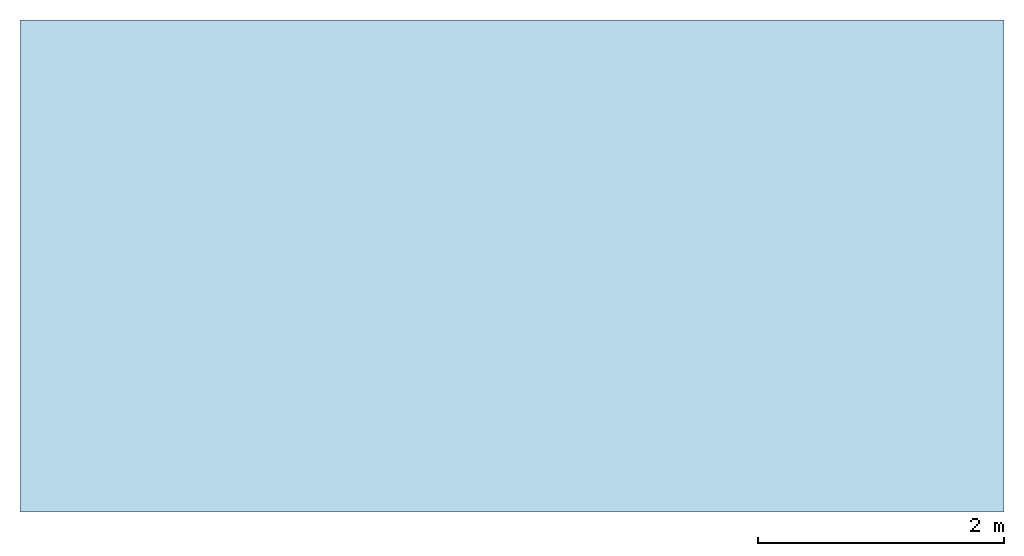
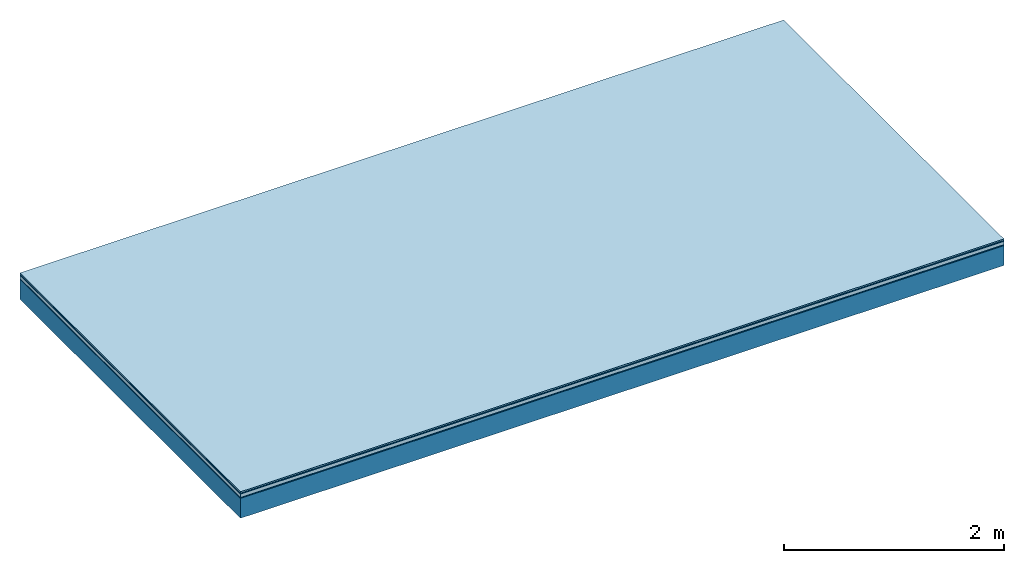
# One storey: 5 plates, 1 member, 1 element without a shape of its own.
"""IFC4 building model written with IfcOpenShell, lengths in metres."""

from ifc_helpers import new_model, si_unit, derived_unit, direction, frame, frame_2d, origin, origin_with_axes, place, context, project, spatial, rectangle, extrude, material, layer, layer_set, type_object, element, aggregate, save


model = new_model("IFC4")

# Units and contexts
plan_context = context("Plan", 3, precision=1e-05, world=origin(), true_north=direction((0.0, 1.0)))
model_context = context("Model", 3, precision=1e-05, world=origin(), true_north=direction((0.0, 1.0)))
ifc_project = project(units=[si_unit("LENGTHUNIT", "METRE"), derived_unit("SOUNDPRESSUREUNIT", [(si_unit("PRESSUREUNIT", "PASCAL", prefix="MICRO"), 0)]), si_unit("ENERGYUNIT", "JOULE", prefix="MEGA"), si_unit("MASSUNIT", "GRAM", prefix="KILO"), derived_unit("THERMALTRANSMITTANCEUNIT", [(si_unit("POWERUNIT", "WATT"), 1), (si_unit("AREAUNIT", "SQUARE_METRE"), -1), (si_unit("THERMODYNAMICTEMPERATUREUNIT", "KELVIN"), -1)]), derived_unit("AREADENSITYUNIT", [(si_unit("MASSUNIT", "GRAM", prefix="KILO"), 1), (si_unit("AREAUNIT", "SQUARE_METRE"), -1)]), derived_unit("USERDEFINED", [(si_unit("ENERGYUNIT", "JOULE", prefix="MEGA"), 1), (si_unit("AREAUNIT", "SQUARE_METRE"), -1)])], contexts=[plan_context, model_context])

# Site, building, storey
site = spatial("IfcSite", under=ifc_project)
building_placement = place(None, origin())
building = spatial("IfcBuilding", under=site, at=building_placement)
storey_placement = place(building_placement, origin())
storey = spatial("IfcBuildingStorey", under=building, at=storey_placement)

# Slab, member, plates
ifc_material_1 = material(Category="11.013")
ifc_layer_1 = layer(ifc_material_1, 0.015, Name="Flooring")
ifc_material_2 = material(Category="03.007")
ifc_layer_2 = layer(ifc_material_2, 0.01, Name="layer")
ifc_material_3 = material(Name="Floor heating system Therm38 standard", Category="03.007")
ifc_layer_3 = layer(ifc_material_3, 0.038, Name="On-material")
ifc_material_4 = material(Name="Wood fiber generic product", Category="10.009")
ifc_layer_4 = layer(ifc_material_4, 0.01, Name="Impact sound insulation")
ifc_material_5 = material(Name="protection", Category="09.007")
ifc_layer_5 = layer(ifc_material_5, 0.0005, Name="Sub-floor")
ifc_material_6 = material(Name="no composite action")
ifc_layer_6 = layer(ifc_material_6, 0.0, Name="Bond")
ifc_layer_7 = layer(None, 0.22, Name="Supporting structure")
ifc_layer_set = layer_set([ifc_layer_1, ifc_layer_2, ifc_layer_3, ifc_layer_4, ifc_layer_5, ifc_layer_6, ifc_layer_7])
slab_type = type_object("IfcSlabType", Name="A2038", PredefinedType="NOTDEFINED", material=ifc_layer_set)
slab_placement = place(None, frame((0.0, 0.0, 0.0), z_axis=(0.0, 0.0, -1.0), x_axis=(1.0, 0.0, 0.0)))
slab = element("IfcSlab", 1, at=slab_placement, inside=storey, type_object=slab_type, material=ifc_layer_set, Name="Slab #1")
ifc_material_7 = material(Name="Solid timber panel")
member_placement = place(slab_placement, origin())
member = element("IfcMember", 2, at=member_placement, material=ifc_material_7, Name="Supporting structure", context=plan_context, shape_type="SweptSolid", body=[
    extrude(rectangle(XDim=1.0, YDim=0.22, at=frame_2d((0.5, 0.11), x_axis=(1.0, 0.0))), frame((0.0, 4.0, 0.0735), z_axis=(0.0, -1.0, 0.0), x_axis=(1.0, 0.0, 0.0)), (0.0, 0.0, 1.0), 4.0),
    extrude(rectangle(XDim=1.0, YDim=0.22, at=frame_2d((0.5, 0.11), x_axis=(1.0, 0.0))), frame((1.0, 4.0, 0.0735), z_axis=(0.0, -1.0, 0.0), x_axis=(1.0, 0.0, 0.0)), (0.0, 0.0, 1.0), 4.0),
    extrude(rectangle(XDim=1.0, YDim=0.22, at=frame_2d((0.5, 0.11), x_axis=(1.0, 0.0))), frame((2.0, 4.0, 0.0735), z_axis=(0.0, -1.0, 0.0), x_axis=(1.0, 0.0, 0.0)), (0.0, 0.0, 1.0), 4.0),
    extrude(rectangle(XDim=1.0, YDim=0.22, at=frame_2d((0.5, 0.11), x_axis=(1.0, 0.0))), frame((3.0, 4.0, 0.0735), z_axis=(0.0, -1.0, 0.0), x_axis=(1.0, 0.0, 0.0)), (0.0, 0.0, 1.0), 4.0),
    extrude(rectangle(XDim=1.0, YDim=0.22, at=frame_2d((0.5, 0.11), x_axis=(1.0, 0.0))), frame((4.0, 4.0, 0.0735), z_axis=(0.0, -1.0, 0.0), x_axis=(1.0, 0.0, 0.0)), (0.0, 0.0, 1.0), 4.0),
    extrude(rectangle(XDim=1.0, YDim=0.22, at=frame_2d((0.5, 0.11), x_axis=(1.0, 0.0))), frame((5.0, 4.0, 0.0735), z_axis=(0.0, -1.0, 0.0), x_axis=(1.0, 0.0, 0.0)), (0.0, 0.0, 1.0), 4.0),
    extrude(rectangle(XDim=1.0, YDim=0.22, at=frame_2d((0.5, 0.11), x_axis=(1.0, 0.0))), frame((6.0, 4.0, 0.0735), z_axis=(0.0, -1.0, 0.0), x_axis=(1.0, 0.0, 0.0)), (0.0, 0.0, 1.0), 4.0),
    extrude(rectangle(XDim=1.0, YDim=0.22, at=frame_2d((0.5, 0.11), x_axis=(1.0, 0.0))), frame((7.0, 4.0, 0.0735), z_axis=(0.0, -1.0, 0.0), x_axis=(1.0, 0.0, 0.0)), (0.0, 0.0, 1.0), 4.0),
])
plate_1_placement = place(slab_placement, origin())
plate_1 = element("IfcPlate", 3, at=plate_1_placement, material=ifc_material_1, Name="Flooring", context=plan_context, shape_type="SweptSolid", body=[
    extrude(rectangle(XDim=8.0, YDim=4.0, at=frame_2d((4.0, 2.0), x_axis=(1.0, 0.0))), origin_with_axes(), (0.0, 0.0, 1.0), 0.015),
])
plate_2_placement = place(slab_placement, origin())
plate_2 = element("IfcPlate", 4, at=plate_2_placement, material=ifc_material_2, Name="layer", context=plan_context, shape_type="SweptSolid", body=[
    extrude(rectangle(XDim=8.0, YDim=4.0, at=frame_2d((4.0, 2.0), x_axis=(1.0, 0.0))), frame((0.0, 0.0, 0.015), z_axis=(0.0, 0.0, 1.0), x_axis=(1.0, 0.0, 0.0)), (0.0, 0.0, 1.0), 0.01),
])
plate_3_placement = place(slab_placement, origin())
plate_3 = element("IfcPlate", 5, at=plate_3_placement, material=ifc_material_3, Name="On-material", context=plan_context, shape_type="SweptSolid", body=[
    extrude(rectangle(XDim=8.0, YDim=4.0, at=frame_2d((4.0, 2.0), x_axis=(1.0, 0.0))), frame((0.0, 0.0, 0.025), z_axis=(0.0, 0.0, 1.0), x_axis=(1.0, 0.0, 0.0)), (0.0, 0.0, 1.0), 0.038),
])
plate_4_placement = place(slab_placement, origin())
plate_4 = element("IfcPlate", 6, at=plate_4_placement, material=ifc_material_4, Name="Impact sound insulation", context=plan_context, shape_type="SweptSolid", body=[
    extrude(rectangle(XDim=8.0, YDim=4.0, at=frame_2d((4.0, 2.0), x_axis=(1.0, 0.0))), frame((0.0, 0.0, 0.063), z_axis=(0.0, 0.0, 1.0), x_axis=(1.0, 0.0, 0.0)), (0.0, 0.0, 1.0), 0.01),
])
plate_5_placement = place(slab_placement, origin())
plate_5 = element("IfcPlate", 7, at=plate_5_placement, material=ifc_material_5, Name="Sub-floor", context=plan_context, shape_type="SweptSolid", body=[
    extrude(rectangle(XDim=8.0, YDim=4.0, at=frame_2d((4.0, 2.0), x_axis=(1.0, 0.0))), frame((0.0, 0.0, 0.073), z_axis=(0.0, 0.0, 1.0), x_axis=(1.0, 0.0, 0.0)), (0.0, 0.0, 1.0), 0.0005),
])
aggregate(slab, [plate_1, plate_2, plate_3, plate_4, plate_5, member])

save(model, "model.ifc")
